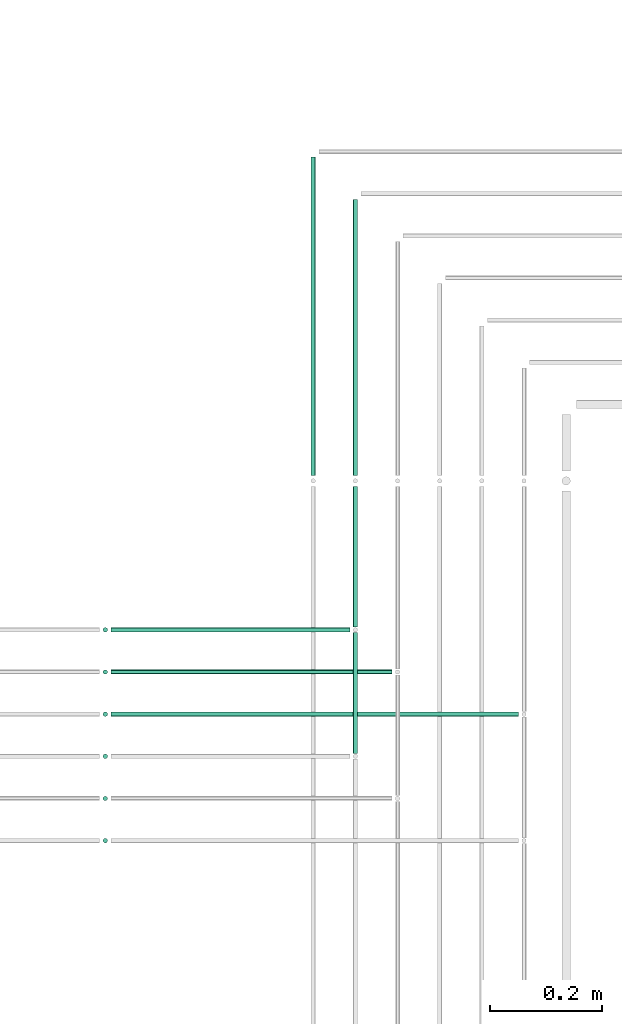
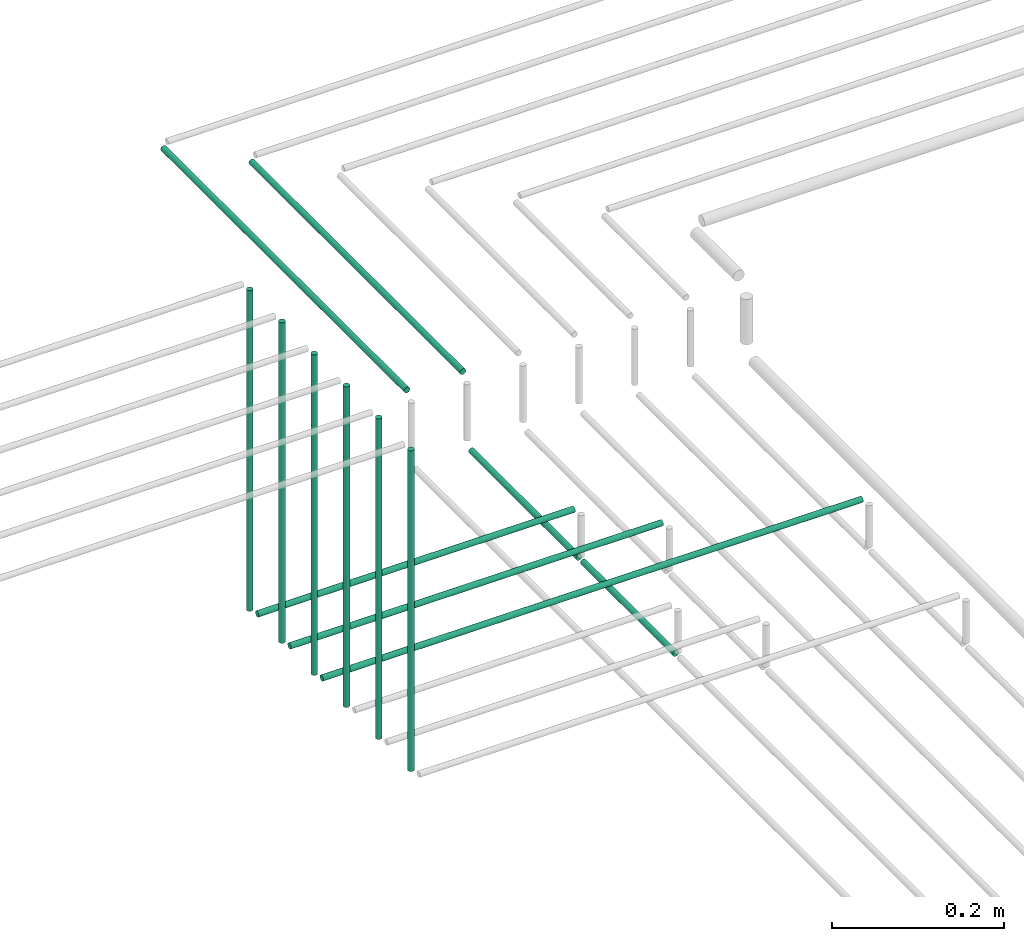
# One storey, part 53 of 89: 13 flow segments.
"""IFC2X3 building model written with IfcOpenShell, lengths in millimetres."""

from ifc_helpers import new_model, entity, si_unit, converted_unit, derived_unit, direction, frame, frame_2d, origin, origin_2d_with_axis, place, context, subcontext, project, spatial, circle, extrude, type_object, element, save


model = new_model("IFC2X3")

# Units and contexts
model_context = context("Model", 3, precision=0.01, world=origin(), true_north=direction((6.12303176911189e-17, 1.0)))
body_context = subcontext(model_context, "Body", "Model", "MODEL_VIEW")
ifc_project = project(units=[si_unit("LENGTHUNIT", "METRE", prefix="MILLI"), si_unit("AREAUNIT", "SQUARE_METRE"), si_unit("VOLUMEUNIT", "CUBIC_METRE"), converted_unit("PLANEANGLEUNIT", "DEGREE", entity("IfcRatioMeasure", 0.0174532925199433), si_unit("PLANEANGLEUNIT", "RADIAN"), dimensions=[0, 0, 0, 0, 0, 0, 0]), si_unit("MASSUNIT", "GRAM", prefix="KILO"), derived_unit("MASSDENSITYUNIT", [(si_unit("MASSUNIT", "GRAM", prefix="KILO"), 1), (si_unit("LENGTHUNIT", "METRE"), -3)]), derived_unit("MOMENTOFINERTIAUNIT", [(si_unit("LENGTHUNIT", "METRE"), 4)]), si_unit("TIMEUNIT", "SECOND"), si_unit("FREQUENCYUNIT", "HERTZ"), si_unit("THERMODYNAMICTEMPERATUREUNIT", "DEGREE_CELSIUS"), derived_unit("THERMALTRANSMITTANCEUNIT", [(si_unit("MASSUNIT", "GRAM", prefix="KILO"), 1), (si_unit("THERMODYNAMICTEMPERATUREUNIT", "KELVIN"), -1), (si_unit("TIMEUNIT", "SECOND"), -3)]), derived_unit("VOLUMETRICFLOWRATEUNIT", [(si_unit("LENGTHUNIT", "METRE"), 3), (si_unit("TIMEUNIT", "SECOND"), -1)]), derived_unit("MASSFLOWRATEUNIT", [(si_unit("MASSUNIT", "GRAM", prefix="KILO"), 1), (si_unit("TIMEUNIT", "SECOND"), -1)]), derived_unit("ROTATIONALFREQUENCYUNIT", [(si_unit("TIMEUNIT", "SECOND"), -1)]), si_unit("ELECTRICCURRENTUNIT", "AMPERE"), si_unit("ELECTRICVOLTAGEUNIT", "VOLT"), si_unit("POWERUNIT", "WATT"), si_unit("FORCEUNIT", "NEWTON", prefix="KILO"), si_unit("ILLUMINANCEUNIT", "LUX"), si_unit("LUMINOUSFLUXUNIT", "LUMEN"), si_unit("LUMINOUSINTENSITYUNIT", "CANDELA"), derived_unit("USERDEFINED", [(si_unit("MASSUNIT", "GRAM", prefix="KILO"), -1), (si_unit("LENGTHUNIT", "METRE"), -2), (si_unit("TIMEUNIT", "SECOND"), 3), (si_unit("LUMINOUSFLUXUNIT", "LUMEN"), 1)]), derived_unit("LINEARVELOCITYUNIT", [(si_unit("LENGTHUNIT", "METRE"), 1), (si_unit("TIMEUNIT", "SECOND"), -1)]), si_unit("PRESSUREUNIT", "PASCAL"), derived_unit("USERDEFINED", [(si_unit("LENGTHUNIT", "METRE"), -2), (si_unit("MASSUNIT", "GRAM", prefix="KILO"), 1), (si_unit("TIMEUNIT", "SECOND"), -2)]), derived_unit("LINEARFORCEUNIT", [(si_unit("MASSUNIT", "GRAM", prefix="KILO"), 1), (si_unit("LENGTHUNIT", "METRE"), 1), (si_unit("TIMEUNIT", "SECOND"), -2), (si_unit("LENGTHUNIT", "METRE"), -1)]), derived_unit("PLANARFORCEUNIT", [(si_unit("MASSUNIT", "GRAM", prefix="KILO"), 1), (si_unit("LENGTHUNIT", "METRE"), 1), (si_unit("TIMEUNIT", "SECOND"), -2), (si_unit("LENGTHUNIT", "METRE"), -2)])], contexts=[model_context])

# Site, building, storey
site_placement = place(None, frame((0.0, -0.00077364408347762, 0.0)))
site = spatial("IfcSite", under=ifc_project, at=site_placement, CompositionType="ELEMENT")
building_placement = place(site_placement, origin())
building = spatial("IfcBuilding", under=site, at=building_placement, CompositionType="ELEMENT")
storey_placement = place(building_placement, frame((0.0, 0.0, 24000.0)))
storey = spatial("IfcBuildingStorey", under=building, at=storey_placement, CompositionType="ELEMENT", Elevation=24000.0)

# Flow segments
pipe_segment_type = type_object("IfcPipeSegmentType", PredefinedType="NOTDEFINED")
flow_segment_1_placement = place(storey_placement, frame((67664.4049963189, 8379.98923132582, 2594.40472776409)))
element("IfcFlowSegment", 1, at=flow_segment_1_placement, inside=storey, type_object=pipe_segment_type, context=body_context, shape_type="SweptSolid", body=[
    extrude(circle(Radius=4.0, at=origin_2d_with_axis()), frame((5.59527223591499, 0.0, 5.59527223591499), z_axis=(0.0, 1.0, 0.0), x_axis=(1.0, 0.0, 0.0)), (0.0, 0.0, 1.0), 250.01076867395),
])
flow_segment_2_placement = place(storey_placement, frame((67664.4049963189, 8154.98923132582, 2594.40472776409)))
element("IfcFlowSegment", 2, at=flow_segment_2_placement, inside=storey, type_object=pipe_segment_type, context=body_context, shape_type="SweptSolid", body=[
    extrude(circle(Radius=4.0, at=origin_2d_with_axis()), frame((5.59527223591499, 0.0, 5.59527223591499), z_axis=(0.0, 1.0, 0.0), x_axis=(1.0, 0.0, 0.0)), (0.0, 0.0, 1.0), 215.0),
])
flow_segment_3_placement = place(storey_placement, frame((67235.1118832776, 8219.39395908988, 2669.40472776407)))
element("IfcFlowSegment", 3, at=flow_segment_3_placement, inside=storey, type_object=pipe_segment_type, context=body_context, shape_type="SweptSolid", body=[
    extrude(circle(Radius=4.0, at=origin_2d_with_axis()), frame((0.0, 5.59527223591607, 5.59527223591499), z_axis=(1.0, 0.0, 0.0), x_axis=(0.0, -1.0, 0.0)), (0.0, 0.0, 1.0), 724.888385277199),
])
flow_segment_4_placement = place(storey_placement, frame((67235.1118832777, 8369.3939590899, 2669.40472776407)))
element("IfcFlowSegment", 4, at=flow_segment_4_placement, inside=storey, type_object=pipe_segment_type, context=body_context, shape_type="SweptSolid", body=[
    extrude(circle(Radius=4.0, at=frame_2d((-1.08286712929839e-12, 0.0), x_axis=(1.0, 0.0))), frame((0.0, 5.59527223591716, 5.59527223591499), z_axis=(1.0, 0.0, 0.0), x_axis=(0.0, 1.0, 0.0)), (0.0, 0.0, 1.0), 424.88838527718),
])
flow_segment_5_placement = place(storey_placement, frame((67235.1118832777, 8294.39395908989, 2669.40472776407)))
element("IfcFlowSegment", 5, at=flow_segment_5_placement, inside=storey, type_object=pipe_segment_type, context=body_context, shape_type="SweptSolid", body=[
    extrude(circle(Radius=4.0, at=frame_2d((5.41433564649196e-12, 0.0), x_axis=(1.0, 0.0))), frame((0.0, 5.59527223592149, 5.59527223591499), z_axis=(1.0, 0.0, 0.0), x_axis=(0.0, 1.0, 0.0)), (0.0, 0.0, 1.0), 499.888385277181),
])
for number, where in (
    (6, (67219.5166110417, 8369.3939590899, 2685.0)),
    (7, (67219.5166110417, 8294.39395908989, 2685.0)),
    (8, (67219.5166110417, 8219.39395908988, 2685.0)),
    (9, (67219.5166110417, 8144.39395908989, 2685.0)),
    (10, (67219.5166110417, 8069.39395908988, 2685.0)),
    (11, (67219.5166110417, 7994.39395908988, 2685.0)),
):
    element("IfcFlowSegment", number, at=place(storey_placement, frame(where)), inside=storey, type_object=pipe_segment_type, context=body_context, shape_type="SweptSolid", body=[
        extrude(circle(Radius=4.0, at=origin_2d_with_axis()), frame((5.59527223591499, 5.59527223591607, 0.0), z_axis=(0.0, 0.0, 1.0), x_axis=(-1.0, 0.0, 0.0)), (0.0, 0.0, 1.0), 455.000000000022),
    ])
flow_segment_6_placement = place(storey_placement, frame((67589.4049963189, 8650.0, 2694.4047277641)))
element("IfcFlowSegment", 12, at=flow_segment_6_placement, inside=storey, type_object=pipe_segment_type, context=body_context, shape_type="SweptSolid", body=[
    extrude(circle(Radius=4.0, at=origin_2d_with_axis()), frame((5.59527223591499, 0.0, 5.59527223591499), z_axis=(0.0, 1.0, 0.0), x_axis=(1.0, 0.0, 0.0)), (0.0, 0.0, 1.0), 565.951299514801),
])
flow_segment_7_placement = place(storey_placement, frame((67664.4049963189, 8650.0, 2694.4047277641)))
element("IfcFlowSegment", 13, at=flow_segment_7_placement, inside=storey, type_object=pipe_segment_type, context=body_context, shape_type="SweptSolid", body=[
    extrude(circle(Radius=4.0, at=origin_2d_with_axis()), frame((5.59527223591499, 0.0, 5.59527223591499), z_axis=(0.0, 1.0, 0.0), x_axis=(1.0, 0.0, 0.0)), (0.0, 0.0, 1.0), 490.951299536116),
])

save(model, "model.ifc")
